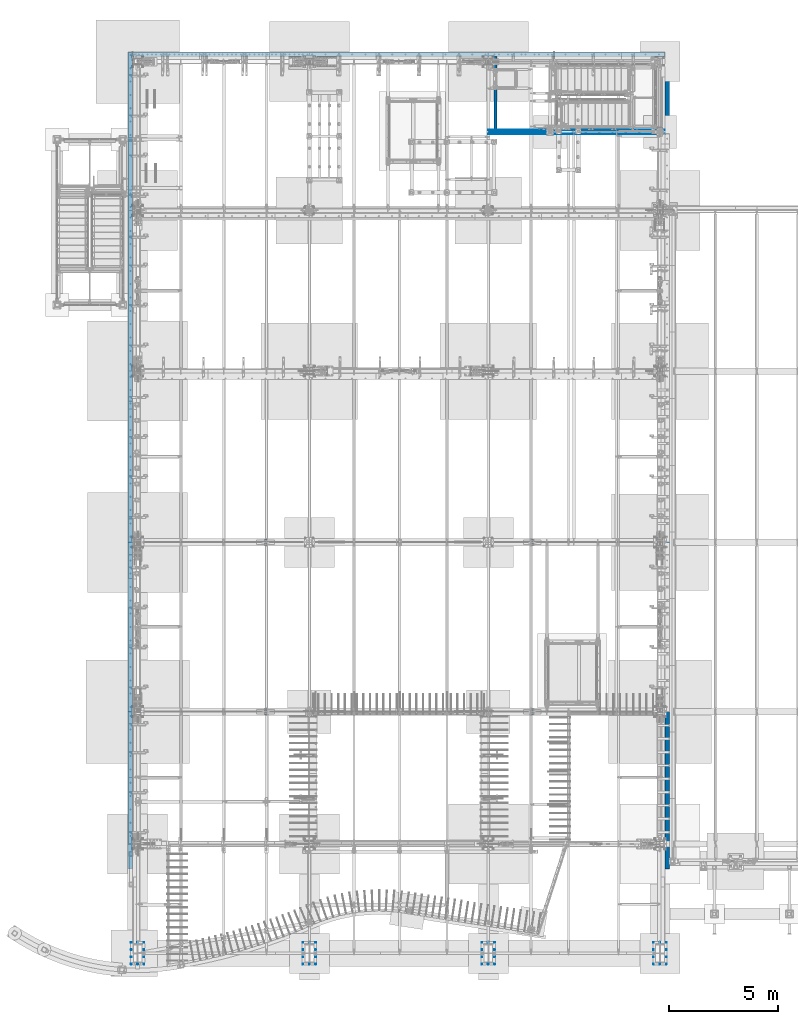
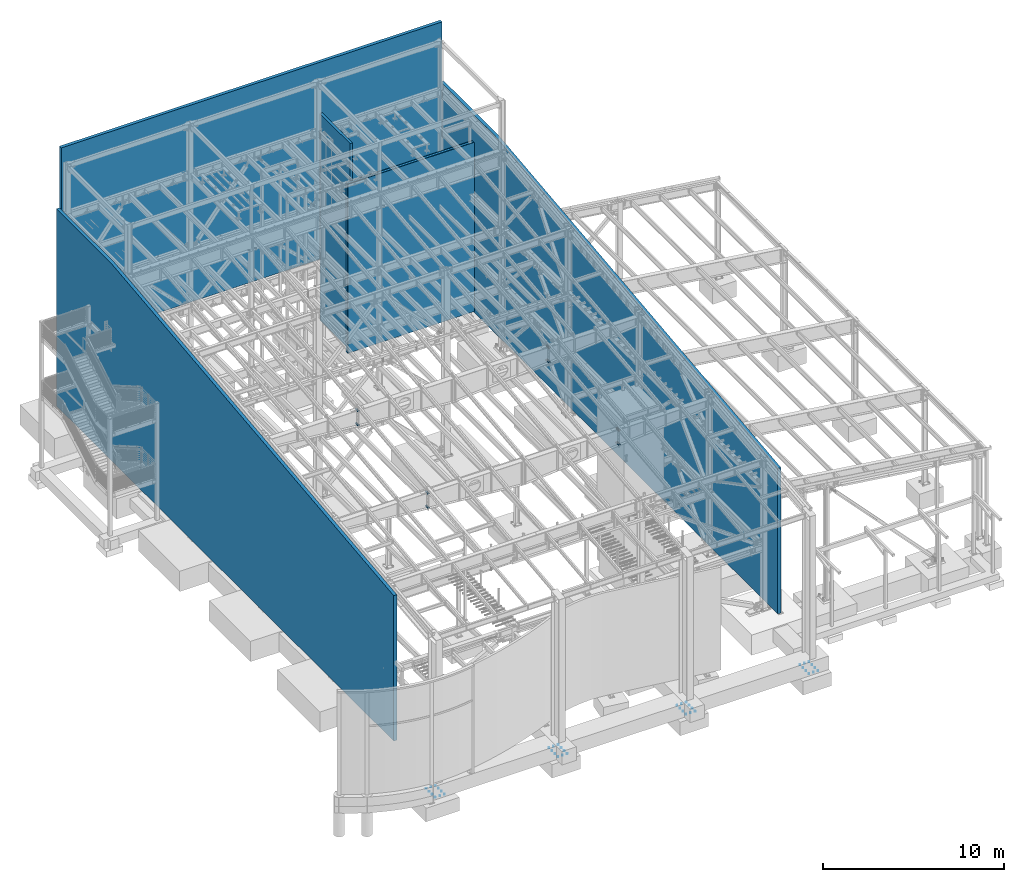
# One storey, part 1 of 1179: 9 walls, 8 mechanical fasteners, 17 elements without a shape of their own.
"""IFC2X3 building model written with IfcOpenShell, lengths in millimetres."""

import ifcopenshell
import ifcopenshell.guid

model = None  # the IFC model being written
_history = None  # IfcOwnerHistory: only IFC2X3 demands one
_inside = {}  # id of a spatial element -> (the spatial element, [elements in it])
_under = {}  # id of a project, library or spatial element -> (it, [spatial elements below it])
_declared = {}  # id of a project -> (the project, [libraries it declares])
_typed = {}  # id of a type object -> (the type object, [elements of that type])
_made_of = {}  # id of a material, layer set ... -> (it, [elements and type objects made of it])


def new_model(schema):
    """Start an empty IFC model of exactly this schema.

    Asked for "IFC4X3", IfcOpenShell would pick the latest addendum, in which some entities
    have other attributes; the version numbers below select the first issue.
    IFC2X3 requires an IfcOwnerHistory on every rooted entity: one is made here for all.
    """
    global model, _history
    if schema == "IFC4X3":
        model = ifcopenshell.file(schema_version=(4, 3, 0, 0))
    else:
        model = ifcopenshell.file(schema=schema)
    _inside.clear()
    _under.clear()
    _declared.clear()
    _typed.clear()
    _made_of.clear()
    _history = None
    if model.schema == "IFC2X3":
        org = make("IfcOrganization", Name="unknown")
        user = make(
            "IfcPersonAndOrganization",
            ThePerson=make("IfcPerson", FamilyName="unknown"),
            TheOrganization=org,
        )
        app = make(
            "IfcApplication",
            ApplicationDeveloper=org,
            Version="unknown",
            ApplicationFullName="unknown",
            ApplicationIdentifier="unknown",
        )
        _history = make(
            "IfcOwnerHistory",
            OwningUser=user,
            OwningApplication=app,
            ChangeAction="ADDED",
            CreationDate=0,
        )
    return model


def make(cls, **values):
    """One entity of the class cls with the attributes given. An attribute that is None is left unset."""
    return model.create_entity(
        cls, **{name: value for name, value in values.items() if value is not None}
    )


def rooted(cls, **values):
    """An entity with a GlobalId (a new one), such as an element, a storey or a relation."""
    return make(cls, GlobalId=ifcopenshell.guid.new(), OwnerHistory=_history, **values)


def si_unit(unit_type, name, prefix=None):
    """IfcSIUnit, for example si_unit("LENGTHUNIT", "METRE", prefix="MILLI")."""
    return make("IfcSIUnit", UnitType=unit_type, Prefix=prefix, Name=name)


def assignment(units):
    """IfcUnitAssignment: the units of a project."""
    return None if units is None else make("IfcUnitAssignment", Units=units)


def point(xyz):
    """IfcCartesianPoint."""
    return None if xyz is None else make("IfcCartesianPoint", Coordinates=xyz)


def direction(xyz):
    """IfcDirection."""
    return None if xyz is None else make("IfcDirection", DirectionRatios=xyz)


def frame(location, z_axis=None, x_axis=None):
    """IfcAxis2Placement3D, a coordinate frame: its origin and axes. An axis left out is left unset."""
    return make(
        "IfcAxis2Placement3D",
        Location=point(location),
        Axis=direction(z_axis),
        RefDirection=direction(x_axis),
    )


def origin_with_axes():
    """The frame at (0, 0, 0) with the z axis (0, 0, 1) and the x axis (1, 0, 0) written out."""
    return frame((0.0, 0.0, 0.0), z_axis=(0.0, 0.0, 1.0), x_axis=(1.0, 0.0, 0.0))


def place(relative_to, where):
    """IfcLocalPlacement: puts the frame where relative to a parent placement (None: the world)."""
    return make(
        "IfcLocalPlacement", PlacementRelTo=relative_to, RelativePlacement=where
    )


def context(
    kind, dimensions, precision=None, world=None, true_north=None, identifier=None
):
    """IfcGeometricRepresentationContext, for example the 3D "Model" context."""
    return make(
        "IfcGeometricRepresentationContext",
        ContextIdentifier=identifier,
        ContextType=kind,
        CoordinateSpaceDimension=dimensions,
        Precision=precision,
        WorldCoordinateSystem=world,
        TrueNorth=true_north,
    )


def subcontext(parent, identifier, kind, view, scale=None):
    """IfcGeometricRepresentationSubContext, for example "Body" below "Model"."""
    return make(
        "IfcGeometricRepresentationSubContext",
        ContextIdentifier=identifier,
        ContextType=kind,
        ParentContext=parent,
        TargetScale=scale,
        TargetView=view,
    )


def project(units=None, contexts=None):
    """IfcProject with its units and contexts."""
    return rooted(
        "IfcProject",
        Name="project",
        RepresentationContexts=contexts,
        UnitsInContext=assignment(units),
    )


def spatial(cls, under=None, at=None, **own):
    """A site, building, storey or space (cls), placed at a placement, below another one or the project."""
    s = rooted(cls, ObjectPlacement=at, **own)
    if under is not None:
        _under.setdefault(under.id(), (under, []))[1].append(s)
    return s


def faces_of(points, faces, orient=None, outer=None):
    """IfcFace entities. A face is a list of loops; a loop is a list of indices into points, from 0.

    orient and outer hold one flag for each loop. By default every Orientation is true, the
    first loop of a face is its IfcFaceOuterBound and the others are IfcFaceBound.
    """
    made = []
    for i, loops in enumerate(faces):
        bounds = []
        for j, loop in enumerate(loops):
            is_outer = j == 0 if outer is None else outer[i][j]
            bounds.append(
                make(
                    "IfcFaceOuterBound" if is_outer else "IfcFaceBound",
                    Bound=make("IfcPolyLoop", Polygon=[points[k] for k in loop]),
                    Orientation=True if orient is None else orient[i][j],
                )
            )
        made.append(make("IfcFace", Bounds=bounds))
    return made


def faceted_brep(points, faces, orient=None, outer=None, voids=None):
    """IfcFacetedBrep: a solid bounded by flat faces; with voids (closed shells), ...WithVoids."""
    shared = [point(p) for p in points]
    hull = make("IfcClosedShell", CfsFaces=faces_of(shared, faces, orient, outer))
    if voids is None:
        return make("IfcFacetedBrep", Outer=hull)
    return make(
        "IfcFacetedBrepWithVoids",
        Outer=hull,
        Voids=[
            make(cls, CfsFaces=faces_of(shared, fs, o, b)) for cls, fs, o, b in voids
        ],
    )


def shape(context_of_items, identifier, shape_type, items):
    """IfcShapeRepresentation: the items that make up one representation, for example the "Body"."""
    return make(
        "IfcShapeRepresentation",
        ContextOfItems=context_of_items,
        RepresentationIdentifier=identifier,
        RepresentationType=shape_type,
        Items=items,
    )


def source(mapping_origin, context_of_items, identifier, shape_type, items):
    """IfcRepresentationMap: a shape defined once, which mapped items show again and again."""
    return make(
        "IfcRepresentationMap",
        MappingOrigin=mapping_origin,
        MappedRepresentation=shape(context_of_items, identifier, shape_type, items),
    )


def transform(
    local_origin,
    x_axis=None,
    y_axis=None,
    z_axis=None,
    scale=None,
    scale2=None,
    scale3=None,
    uniform=True,
):
    """IfcCartesianTransformationOperator3D, or its non-uniform kind. x_axis, y_axis, z_axis: its Axis1, 2, 3."""
    if uniform:
        return make(
            "IfcCartesianTransformationOperator3D",
            Axis1=direction(x_axis),
            Axis2=direction(y_axis),
            LocalOrigin=point(local_origin),
            Scale=scale,
            Axis3=direction(z_axis),
        )
    return make(
        "IfcCartesianTransformationOperator3DnonUniform",
        Axis1=direction(x_axis),
        Axis2=direction(y_axis),
        LocalOrigin=point(local_origin),
        Scale=scale,
        Axis3=direction(z_axis),
        Scale2=scale2,
        Scale3=scale3,
    )


def mapped(mapping_source, mapping_target):
    """IfcMappedItem: shows the shape of a source again, moved by a transform."""
    return make(
        "IfcMappedItem", MappingSource=mapping_source, MappingTarget=mapping_target
    )


def material(Name=None, Category=None):
    """IfcMaterial."""
    return make("IfcMaterial", Name=Name, Category=Category)


def made_of(thing, what):
    """Note that an element or type object is made of a material, layer set ...; save() writes the relation."""
    if what is not None:
        _made_of.setdefault(what.id(), (what, []))[1].append(thing)
    return thing


def type_object(cls, material=None, **own):
    """A type object (cls), such as IfcWallType, which elements share."""
    return made_of(rooted(cls, **own), material)


def element(
    cls,
    number,
    at=None,
    inside=None,
    cuts=None,
    type_object=None,
    material=None,
    context=None,
    identifier="Body",
    shape_type=None,
    held_by="IfcProductDefinitionShape",
    body=None,
    shapes=None,
    **own,
):
    """One element of the class cls, such as IfcWall. Its Tag is "e" and its number.

    at: its placement. inside: the storey or other place that contains it. cuts: it is an
    opening in that element (IfcRelVoidsElement). A single representation is given by context,
    identifier, shape_type and body (its items); several are given by shapes. held_by: the class
    of the entity that holds the representations. save() writes the other relations.
    """
    e = rooted(cls, Tag="e%d" % number, ObjectPlacement=at, **own)
    if body is not None:
        shapes = [shape(context, identifier, shape_type, body)]
    if shapes is not None:
        e.Representation = make(held_by, Representations=shapes)
    if inside is not None:
        _inside.setdefault(inside.id(), (inside, []))[1].append(e)
    if cuts is not None:
        rooted(
            "IfcRelVoidsElement", RelatingBuildingElement=cuts, RelatedOpeningElement=e
        )
    if type_object is not None:
        _typed.setdefault(type_object.id(), (type_object, []))[1].append(e)
    return made_of(e, material)


def aggregate(whole, parts):
    """IfcRelAggregates: a whole, such as a stair, and the parts it consists of."""
    return rooted("IfcRelAggregates", RelatingObject=whole, RelatedObjects=parts)


def save(model, path):
    """Write the relations noted so far, then the file.

    IfcRelAggregates (storeys below a building ...), IfcRelContainedInSpatialStructure (elements
    in a storey), IfcRelDefinesByType, IfcRelAssociatesMaterial and IfcRelDeclares: one each for
    every whole, place, type object, material and project.
    """
    for whole, parts in _under.values():
        aggregate(whole, parts)
    for where, things in _inside.values():
        rooted(
            "IfcRelContainedInSpatialStructure",
            RelatedElements=things,
            RelatingStructure=where,
        )
    for kind, things in _typed.values():
        rooted("IfcRelDefinesByType", RelatedObjects=things, RelatingType=kind)
    for what, things in _made_of.values():
        rooted("IfcRelAssociatesMaterial", RelatedObjects=things, RelatingMaterial=what)
    for by, libraries in _declared.values():
        rooted("IfcRelDeclares", RelatingContext=by, RelatedDefinitions=libraries)
    model.write(path)


model = new_model("IFC2X3")

# Units and contexts
model_context = context("Model", 3, precision=1e-05, world=origin_with_axes())
body_context = subcontext(model_context, "Body", "Model", "MODEL_VIEW")
ifc_project = project(units=[si_unit("LENGTHUNIT", "METRE", prefix="MILLI"), si_unit("AREAUNIT", "SQUARE_METRE"), si_unit("VOLUMEUNIT", "CUBIC_METRE"), si_unit("MASSUNIT", "GRAM", prefix="KILO"), si_unit("TIMEUNIT", "SECOND"), si_unit("PLANEANGLEUNIT", "RADIAN"), si_unit("SOLIDANGLEUNIT", "STERADIAN"), si_unit("THERMODYNAMICTEMPERATUREUNIT", "DEGREE_CELSIUS"), si_unit("LUMINOUSINTENSITYUNIT", "LUMEN")], contexts=[model_context])

# Site, building, storey
site_placement = place(None, origin_with_axes())
site = spatial("IfcSite", under=ifc_project, at=site_placement, CompositionType="ELEMENT")
building_placement = place(site_placement, origin_with_axes())
building = spatial("IfcBuilding", under=site, at=building_placement, Name="Undefined", CompositionType="ELEMENT")
storey_placement = place(building_placement, origin_with_axes())
storey = spatial("IfcBuildingStorey", under=building, at=storey_placement, Name="Undefined", CompositionType="ELEMENT", Elevation=0.0)

# Assembly, wall
assembly_1_placement = place(storey_placement, origin_with_axes())
assembly_1 = element("IfcElementAssembly", 1, at=assembly_1_placement, inside=storey, Name="GYP. BOARD", AssemblyPlace="NOTDEFINED", PredefinedType="REINFORCEMENT_UNIT")
ifc_material_1 = material(Name="CONCRETE/5000")
wall_type_1 = type_object("IfcWallType", PredefinedType="NOTDEFINED")
wall_1_placement = place(assembly_1_placement, frame((16459.2, 37901.5625000252, 5715.0), z_axis=(0.0, 0.0, 1.0), x_axis=(1.0, 0.0, 0.0)))
wall_1 = element("IfcWall", 2, at=wall_1_placement, type_object=wall_type_1, material=ifc_material_1, Name="GYP. BOARD", context=body_context, shape_type="Brep", body=[
    faceted_brep([(0.0, 7.9375, -5715.0), (0.0, 7.9375, 5715.0), (8077.2, 7.9375, 5715.0), (8077.2, 7.9375, -5715.0), (0.0, -7.9375, 5715.0), (8077.2, -7.9375, 5715.0), (0.0, -7.9375, -5715.0), (8077.2, -7.9375, -5715.0)], [[[0, 1, 2, 3]], [[1, 4, 5, 2]], [[4, 6, 7, 5]], [[6, 0, 3, 7]], [[5, 7, 3, 2]], [[6, 4, 1, 0]]]),
])
aggregate(assembly_1, [wall_1])

assembly_2_placement = place(storey_placement, origin_with_axes())
assembly_2 = element("IfcElementAssembly", 3, at=assembly_2_placement, inside=storey, Name="GYP. BOARD", AssemblyPlace="NOTDEFINED", PredefinedType="REINFORCEMENT_UNIT")
wall_2_placement = place(assembly_2_placement, frame((16459.2, 37885.6875000252, 5715.0), z_axis=(0.0, 0.0, 1.0), x_axis=(1.0, 0.0, 0.0)))
wall_2 = element("IfcWall", 4, at=wall_2_placement, type_object=wall_type_1, material=ifc_material_1, Name="GYP. BOARD", context=body_context, shape_type="Brep", body=[
    faceted_brep([(0.0, 7.9375, -5715.0), (0.0, 7.9375, 5715.0), (8077.2, 7.9375, 5715.0), (8077.2, 7.9375, -5715.0), (0.0, -7.9375, 5715.0), (8077.2, -7.9375, 5715.0), (0.0, -7.9375, -5715.0), (8077.2, -7.9375, -5715.0)], [[[0, 1, 2, 3]], [[1, 4, 5, 2]], [[4, 6, 7, 5]], [[6, 0, 3, 7]], [[5, 7, 3, 2]], [[6, 4, 1, 0]]]),
])
aggregate(assembly_2, [wall_2])

assembly_3_placement = place(storey_placement, origin_with_axes())
assembly_3 = element("IfcElementAssembly", 5, at=assembly_3_placement, inside=storey, Name="GYP. BOARD", AssemblyPlace="NOTDEFINED", PredefinedType="REINFORCEMENT_UNIT")
wall_3_placement = place(assembly_3_placement, frame((16459.2, 38085.7125, 5715.0), z_axis=(0.0, 0.0, 1.0), x_axis=(1.0, 0.0, 0.0)))
wall_3 = element("IfcWall", 6, at=wall_3_placement, type_object=wall_type_1, material=ifc_material_1, Name="GYP. BOARD", context=body_context, shape_type="Brep", body=[
    faceted_brep([(0.0, 7.9375, -5715.0), (0.0, 7.9375, 5715.0), (8077.2, 7.9375, 5715.0), (8077.2, 7.9375, -5715.0), (0.0, -7.9375, 5715.0), (8077.2, -7.9375, 5715.0), (0.0, -7.9375, -5715.0), (8077.2, -7.9375, -5715.0)], [[[0, 1, 2, 3]], [[1, 4, 5, 2]], [[4, 6, 7, 5]], [[6, 0, 3, 7]], [[5, 7, 3, 2]], [[6, 4, 1, 0]]]),
])
aggregate(assembly_3, [wall_3])

assembly_4_placement = place(storey_placement, origin_with_axes())
assembly_4 = element("IfcElementAssembly", 7, at=assembly_4_placement, inside=storey, Name="GYP. BOARD", AssemblyPlace="NOTDEFINED", PredefinedType="REINFORCEMENT_UNIT")
wall_4_placement = place(assembly_4_placement, frame((16459.2, 38069.8375, 5715.0), z_axis=(0.0, 0.0, 1.0), x_axis=(1.0, 0.0, 0.0)))
wall_4 = element("IfcWall", 8, at=wall_4_placement, type_object=wall_type_1, material=ifc_material_1, Name="GYP. BOARD", context=body_context, shape_type="Brep", body=[
    faceted_brep([(0.0, 7.9375, -5715.0), (0.0, 7.9375, 5715.0), (8077.2, 7.9375, 5715.0), (8077.2, 7.9375, -5715.0), (0.0, -7.9375, 5715.0), (8077.2, -7.9375, 5715.0), (0.0, -7.9375, -5715.0), (8077.2, -7.9375, -5715.0)], [[[0, 1, 2, 3]], [[1, 4, 5, 2]], [[4, 6, 7, 5]], [[6, 0, 3, 7]], [[5, 7, 3, 2]], [[6, 4, 1, 0]]]),
])
aggregate(assembly_4, [wall_4])

assembly_5_placement = place(storey_placement, origin_with_axes())
assembly_5 = element("IfcElementAssembly", 9, at=assembly_5_placement, inside=storey, Name="WALL", AssemblyPlace="NOTDEFINED", PredefinedType="REINFORCEMENT_UNIT")
wall_type_2 = type_object("IfcWallType", PredefinedType="NOTDEFINED")
wall_5_placement = place(assembly_5_placement, frame((203.199999999999, 41529.0, 10760.075), z_axis=(0.0, 0.0, 1.0), x_axis=(1.0, 0.0, 0.0)))
wall_5 = element("IfcWall", 10, at=wall_5_placement, type_object=wall_type_2, material=ifc_material_1, Name="WALL", context=body_context, shape_type="Brep", body=[
    faceted_brep([(0.0, 101.599999999999, -6657.975), (0.0, 101.599999999999, 6657.975), (24333.2007038869, 101.599999999999, 6657.975), (24333.2007038869, 101.599999999999, -6657.975), (0.0, -101.599999999999, 6657.975), (24333.2007038869, -101.599999999999, 6657.975), (0.0, -101.599999999999, -6657.975), (24333.2007038869, -101.599999999999, -6657.975)], [[[0, 1, 2, 3]], [[1, 4, 5, 2]], [[4, 6, 7, 5]], [[6, 0, 3, 7]], [[5, 7, 3, 2]], [[6, 4, 1, 0]]]),
])
aggregate(assembly_5, [wall_5])

assembly_6_placement = place(storey_placement, origin_with_axes())
assembly_6 = element("IfcElementAssembly", 11, at=assembly_6_placement, inside=storey, Name="WALL", AssemblyPlace="NOTDEFINED", PredefinedType="REINFORCEMENT_UNIT")
wall_6_placement = place(assembly_6_placement, frame((101.599999999999, 4292.60000000001, 6594.475), z_axis=(0.0, 0.0, 1.0), x_axis=(0.0, 1.0, 0.0)))
wall_6 = element("IfcWall", 12, at=wall_6_placement, type_object=wall_type_2, material=ifc_material_1, Name="WALL", context=body_context, shape_type="Brep", body=[
    faceted_brep([(0.0, -101.599999999999, -6657.975), (0.0, 101.599999999999, -6657.975), (37338.0, 101.6, -6657.975), (37338.0, -101.6, -6657.975), (37338.0, -101.6, 6657.975), (37338.0, 101.6, 6657.975), (31293.1291769072, -101.6, 6657.975), (0.0, -101.6, 3163.4294703688), (0.0, 101.6, 3163.4294703688), (31293.1291769072, 101.6, 6657.975)], [[[0, 1, 2, 3]], [[4, 3, 2, 5]], [[0, 3, 4, 6, 7]], [[1, 0, 7, 8]], [[5, 2, 1, 8, 9]], [[4, 5, 9, 6]], [[8, 7, 6, 9]]]),
])
aggregate(assembly_6, [wall_6])

assembly_7_placement = place(storey_placement, origin_with_axes())
assembly_7 = element("IfcElementAssembly", 13, at=assembly_7_placement, inside=storey, Name="WALL", AssemblyPlace="NOTDEFINED", PredefinedType="REINFORCEMENT_UNIT")
wall_7_placement = place(assembly_7_placement, frame((24638.0007038869, 4292.6, 6594.475), z_axis=(0.0, 0.0, 1.0), x_axis=(0.0, 1.0, 0.0)))
wall_7 = element("IfcWall", 14, at=wall_7_placement, type_object=wall_type_2, material=ifc_material_1, Name="WALL", context=body_context, shape_type="Brep", body=[
    faceted_brep([(0.0, -101.599999999999, -6657.975), (0.0, 101.599999999999, -6657.975), (37338.0, 101.6, -6657.975), (37338.0, -101.6, -6657.975), (37338.0, -101.6, 6657.975), (37338.0, 101.6, 6657.975), (31293.1291769072, -101.6, 6657.975), (0.0, -101.6, 3163.4294703688), (0.0, 101.6, 3163.4294703688), (31293.1291769072, 101.6, 6657.975)], [[[0, 1, 2, 3]], [[4, 3, 2, 5]], [[0, 3, 4, 6, 7]], [[1, 0, 7, 8]], [[5, 2, 1, 8, 9]], [[4, 5, 9, 6]], [[8, 7, 6, 9]]]),
])
aggregate(assembly_7, [wall_7])

assembly_8_placement = place(storey_placement, origin_with_axes())
assembly_8 = element("IfcElementAssembly", 15, at=assembly_8_placement, inside=storey, Name="WALL", AssemblyPlace="NOTDEFINED", PredefinedType="REINFORCEMENT_UNIT")
wall_type_3 = type_object("IfcWallType", PredefinedType="NOTDEFINED")
wall_8_placement = place(assembly_8_placement, frame((16789.4, 38061.9, 6985.0), z_axis=(0.0, 0.0, 1.0), x_axis=(0.0, 1.0, 0.0)))
wall_8 = element("IfcWall", 16, at=wall_8_placement, type_object=wall_type_3, material=ifc_material_1, Name="WALL", context=body_context, shape_type="Brep", body=[
    faceted_brep([(0.0, 76.2000000000007, -6985.0), (0.0, 76.2000000000007, 6985.0), (3365.50000000001, 76.2000000000007, 6985.0), (3365.50000000001, 76.2000000000007, -6985.0), (0.0, -76.2000000000007, 6985.0), (3365.50000000001, -76.2000000000007, 6985.0), (0.0, -76.2000000000007, -6985.0), (3365.50000000001, -76.2000000000007, -6985.0)], [[[0, 1, 2, 3]], [[1, 4, 5, 2]], [[4, 6, 7, 5]], [[6, 0, 3, 7]], [[5, 7, 3, 2]], [[6, 4, 1, 0]]]),
])
aggregate(assembly_8, [wall_8])

assembly_9_placement = place(storey_placement, origin_with_axes())
assembly_9 = element("IfcElementAssembly", 17, at=assembly_9_placement, inside=storey, Name="WALL", AssemblyPlace="NOTDEFINED", PredefinedType="REINFORCEMENT_UNIT")
wall_type_4 = type_object("IfcWallType", PredefinedType="NOTDEFINED")
wall_9_placement = place(assembly_9_placement, frame((16459.2, 37985.7, 5715.0), z_axis=(0.0, 0.0, 1.0), x_axis=(1.0, 0.0, 0.0)))
wall_9 = element("IfcWall", 18, at=wall_9_placement, type_object=wall_type_4, material=ifc_material_1, Name="WALL", context=body_context, shape_type="Brep", body=[
    faceted_brep([(0.0, 76.1999999999971, -5715.0), (0.0, 76.1999999999971, 5715.0), (8077.2, 76.1999999999971, 5715.0), (8077.2, 76.1999999999971, -5715.0), (0.0, -76.1999999999971, 5715.0), (8077.2, -76.1999999999971, 5715.0), (0.0, -76.1999999999971, -5715.0), (8077.2, -76.1999999999971, -5715.0)], [[[0, 1, 2, 3]], [[1, 4, 5, 2]], [[4, 6, 7, 5]], [[6, 0, 3, 7]], [[5, 7, 3, 2]], [[6, 4, 1, 0]]]),
])
aggregate(assembly_9, [wall_9])

# Assembly, mechanical fastener
assembly_10_placement = place(storey_placement, origin_with_axes())
assembly_10 = element("IfcElementAssembly", 19, at=assembly_10_placement, inside=storey, Name="RAFTER BEAM", AssemblyPlace="NOTDEFINED", PredefinedType="RIGID_FRAME")
ifc_material_2 = material(Name="Undefined")
mechanical_fastener_type = type_object("IfcMechanicalFastenerType", Name="Bolt assembly")
shared_shape_1 = source(origin_with_axes(), body_context, "Body", "Brep", [
    faceted_brep([(17.9605119723985, -40.4812501907356, 0.0), (12.6999998092651, -40.4812501907356, 12.6999998092651), (1.09976417490228e-15, -40.4812501907356, 17.9605119723985), (-12.6999998092651, -40.4812501907356, 12.6999998092651), (-17.9605119723985, -40.4812501907356, 2.19952834980455e-15), (-12.6999998092651, -40.4812501907356, -12.6999998092651), (-3.29929252470683e-15, -40.4812501907356, -17.9605119723985), (12.6999998092651, -40.4812501907356, -12.6999998092651), (20.6375007629394, -25.4000000000007, -20.6375007629395), (-5.36135063136961e-15, -25.4000000000007, -29.1858334724341), (-20.6375007629395, -25.4000000000007, -20.6375007629394), (-29.1858334724341, -25.4000000000007, 3.57423375424641e-15), (-20.6375007629394, -25.4000000000007, 20.6375007629395), (1.7871168771232e-15, -25.4000000000007, 29.1858334724341), (20.6375007629395, -25.4000000000007, 20.6375007629395), (29.1858334724341, -25.4000000000007, 0.0), (12.6999998092651, -25.4000000000007, 0.0), (10.9985224628809, -25.4000000000007, 6.34999990463295), (6.34999990463181, -25.4000000000007, 10.9985224628816), (-1.31614667686587e-12, -25.4000000000007, 12.6999998092651), (-6.34999990463409, -25.4000000000007, 10.9985224628803), (-10.9985224628822, -25.4000000000007, 6.34999990463067), (-12.6999998092651, -25.4000000000007, -2.63229335373174e-12), (-10.9985224628796, -25.4000000000007, -6.34999990463522), (-6.34999990462954, -25.4000000000007, -10.9985224628829), (3.93434019839663e-12, -25.4000000000007, -12.6999998092651), (6.34999990463636, -25.4000000000007, -10.9985224628789), (10.9985224628835, -25.4000000000007, -6.34999990462839), (10.9985224628835, 63.5000015258782, -6.34999990462839), (6.34999990463636, 63.5000015258782, -10.9985224628789), (3.93434019839663e-12, 63.5000015258782, -12.6999998092651), (-6.34999990462954, 63.5000015258782, -10.9985224628829), (-10.9985224628796, 63.5000015258782, -6.34999990463522), (-12.6999998092651, 63.5000015258782, -2.63229335373174e-12), (-10.9985224628822, 63.5000015258782, 6.34999990463067), (-6.34999990463409, 63.5000015258782, 10.9985224628803), (-1.31614667686587e-12, 63.5000015258782, 12.6999998092651), (6.34999990463181, 63.5000015258782, 10.9985224628816), (10.9985224628809, 63.5000015258782, 6.34999990463295), (12.6999998092651, 63.5000015258782, 0.0), (25.3999996185303, 25.4000000000007, 0.0), (21.9970449257618, 25.4000000000007, 12.6999998092659), (12.6999998092636, 25.4000000000007, 21.9970449257631), (0.0, 25.3999999999996, 25.4000000000015), (-12.6999998092682, 25.4000000000007, 21.9970449257605), (-21.9970449257645, 25.4000000000007, 12.6999998092613), (-25.3999996185303, 25.4000000000007, -5.26458670746348e-12), (-21.9970449257592, 25.4000000000007, -12.6999998092704), (-12.6999998092591, 25.4000000000007, -21.9970449257658), (0.0, 25.3999999999996, -25.4000000000015), (12.6999998092727, 25.4000000000007, -21.9970449257579), (21.9970449257671, 25.4000000000007, -12.6999998092568), (21.9970449257671, 28.7734400272377, -12.6999998092568), (12.6999998092727, 28.7734400272377, -21.9970449257579), (7.86868039679326e-12, 28.7734400272377, -25.3999996185303), (-12.6999998092591, 28.7734400272377, -21.9970449257658), (-21.9970449257592, 28.7734400272377, -12.6999998092704), (-25.3999996185303, 28.7734400272377, -5.26458670746348e-12), (-21.9970449257645, 28.7734400272377, 12.6999998092613), (-12.6999998092682, 28.7734400272377, 21.9970449257605), (-2.63229335373174e-12, 28.7734400272377, 25.3999996185303), (12.6999998092636, 28.7734400272377, 21.9970449257631), (21.9970449257618, 28.7734400272377, 12.6999998092659), (25.3999996185303, 28.7734400272377, 0.0), (23.8301332417684, 28.7734400272377, 0.0), (11.9150666208842, 28.7734400272377, 20.6375007629395), (-11.9150666208842, 28.7734400272377, 20.6375007629395), (-23.8301332417684, 28.7734400272377, 2.91834963977866e-15), (-11.9150666208842, 28.7734400272377, -20.6375007629394), (11.9150666208842, 28.7734400272377, -20.6375007629395), (11.9150666208842, 54.1734396457679, -20.6375007629395), (-11.9150666208842, 54.1734396457679, -20.6375007629394), (-23.8301332417684, 54.1734396457679, 2.91834963977866e-15), (-11.9150666208842, 54.1734396457679, 20.6375007629395), (11.9150666208842, 54.1734396457679, 20.6375007629395), (23.8301332417684, 54.1734396457679, 0.0)], [[[0, 1, 2, 3, 4, 5, 6, 7]], [[8, 9, 10, 11, 12, 13, 14, 15]], [[0, 15, 14, 1]], [[1, 14, 13, 2]], [[2, 13, 12, 3]], [[3, 12, 11, 4]], [[4, 11, 10, 5]], [[5, 10, 9, 6]], [[6, 9, 8, 7]], [[7, 8, 15, 0]], [[16, 17, 18, 19, 20, 21, 22, 23, 24, 25, 26, 27]], [[28, 29, 30, 31, 32, 33, 34, 35, 36, 37, 38, 39]], [[16, 39, 38, 17]], [[17, 38, 37, 18]], [[18, 37, 36, 19]], [[19, 36, 35, 20]], [[20, 35, 34, 21]], [[21, 34, 33, 22]], [[22, 33, 32, 23]], [[23, 32, 31, 24]], [[24, 31, 30, 25]], [[25, 30, 29, 26]], [[26, 29, 28, 27]], [[27, 28, 39, 16]], [[40, 41, 42, 43, 44, 45, 46, 47, 48, 49, 50, 51]], [[52, 53, 54, 55, 56, 57, 58, 59, 60, 61, 62, 63]], [[40, 63, 62, 41]], [[41, 62, 61, 42]], [[42, 61, 60, 43]], [[43, 60, 59, 44]], [[44, 59, 58, 45]], [[45, 58, 57, 46]], [[46, 57, 56, 47]], [[47, 56, 55, 48]], [[48, 55, 54, 49]], [[49, 54, 53, 50]], [[50, 53, 52, 51]], [[51, 52, 63, 40]], [[64, 65, 66, 67, 68, 69]], [[70, 71, 72, 73, 74, 75]], [[64, 75, 74, 65]], [[65, 74, 73, 66]], [[66, 73, 72, 67]], [[67, 72, 71, 68]], [[68, 71, 70, 69]], [[69, 70, 75, 64]]]),
    faceted_brep([(13.4937496185303, -0.0999999999992753, 0.0), (11.6859299619536, -0.0999999999992753, 6.74687480926554), (6.74687480926433, -0.0999999999992753, 11.6859299619543), (-1.39840582563885e-12, -0.0999999999992753, 13.4937496185303), (-6.74687480926675, -0.0999999999992753, 11.6859299619529), (-11.685929961955, -0.0999999999992753, 6.74687480926312), (-13.4937496185303, -0.0999999999992753, -2.79681165127771e-12), (-11.6859299619522, -0.0999999999992753, -6.74687480926796), (-6.74687480926191, -0.0999999999992753, -11.6859299619557), (4.18023640540155e-12, -0.0999999999992753, -13.4937496185303), (6.74687480926917, -0.0999999999992753, -11.6859299619515), (11.6859299619564, -0.0999999999992753, -6.7468748092607), (11.6859299619564, 25.4000000000007, -6.7468748092607), (6.74687480926917, 25.4000000000007, -11.6859299619515), (4.18023640540155e-12, 25.4000000000007, -13.4937496185303), (-6.74687480926191, 25.4000000000007, -11.6859299619557), (-11.6859299619522, 25.4000000000007, -6.74687480926796), (-13.4937496185303, 25.4000000000007, -2.79681165127771e-12), (-11.685929961955, 25.4000000000007, 6.74687480926312), (-6.74687480926675, 25.4000000000007, 11.6859299619529), (-1.39840582563885e-12, 25.4000000000007, 13.4937496185303), (6.74687480926433, 25.4000000000007, 11.6859299619543), (11.6859299619536, 25.4000000000007, 6.74687480926554), (13.4937496185303, 25.4000000000007, 0.0), (13.4937496185303, -25.3000000000007, 0.0), (11.6859299619536, -25.3000000000007, 6.74687480926554), (6.74687480926433, -25.3000000000007, 11.6859299619543), (-1.39840582563885e-12, -25.3000000000007, 13.4937496185303), (-6.74687480926675, -25.3000000000007, 11.6859299619529), (-11.685929961955, -25.3000000000007, 6.74687480926312), (-13.4937496185303, -25.3000000000007, -2.79681165127771e-12), (-11.6859299619522, -25.3000000000007, -6.74687480926796), (-6.74687480926191, -25.3000000000007, -11.6859299619557), (4.18023640540155e-12, -25.3000000000007, -13.4937496185303), (6.74687480926917, -25.3000000000007, -11.6859299619515), (11.6859299619564, -25.3000000000007, -6.7468748092607), (11.6859299619564, 0.0999999999992767, -6.7468748092607), (6.74687480926917, 0.0999999999992767, -11.6859299619515), (4.18023640540155e-12, 0.0999999999992767, -13.4937496185303), (-6.74687480926191, 0.0999999999992767, -11.6859299619557), (-11.6859299619522, 0.0999999999992767, -6.74687480926796), (-13.4937496185303, 0.0999999999992767, -2.79681165127771e-12), (-11.685929961955, 0.0999999999992767, 6.74687480926312), (-6.74687480926675, 0.0999999999992767, 11.6859299619529), (-1.39840582563885e-12, 0.0999999999992767, 13.4937496185303), (6.74687480926433, 0.0999999999992767, 11.6859299619543), (11.6859299619536, 0.0999999999992767, 6.74687480926554), (13.4937496185303, 0.0999999999992767, 0.0)], [[[0, 1, 2, 3, 4, 5, 6, 7, 8, 9, 10, 11]], [[12, 13, 14, 15, 16, 17, 18, 19, 20, 21, 22, 23]], [[0, 23, 22, 1]], [[1, 22, 21, 2]], [[2, 21, 20, 3]], [[3, 20, 19, 4]], [[4, 19, 18, 5]], [[5, 18, 17, 6]], [[6, 17, 16, 7]], [[7, 16, 15, 8]], [[8, 15, 14, 9]], [[9, 14, 13, 10]], [[10, 13, 12, 11]], [[11, 12, 23, 0]], [[24, 25, 26, 27, 28, 29, 30, 31, 32, 33, 34, 35]], [[36, 37, 38, 39, 40, 41, 42, 43, 44, 45, 46, 47]], [[24, 47, 46, 25]], [[25, 46, 45, 26]], [[26, 45, 44, 27]], [[27, 44, 43, 28]], [[28, 43, 42, 29]], [[29, 42, 41, 30]], [[30, 41, 40, 31]], [[31, 40, 39, 32]], [[32, 39, 38, 33]], [[33, 38, 37, 34]], [[34, 37, 36, 35]], [[35, 36, 47, 24]]]),
])
mechanical_fastener_1_placement = place(assembly_10_placement, frame((18465.8, 11607.8093353614, 9698.05885710149), z_axis=(0.0, 0.0, 1.0), x_axis=(0.0, -1.0, 0.0)))
mechanical_fastener_1 = element("IfcMechanicalFastener", 20, at=mechanical_fastener_1_placement, type_object=mechanical_fastener_type, material=ifc_material_2, Name="Bolt assembly", NominalDiameter=25.3999996185303, NominalLength=88.9000015258789, context=body_context, shape_type="MappedRepresentation", body=[
    mapped(shared_shape_1, transform((0.0, 0.0, -481.015014500001))),
    mapped(shared_shape_1, transform((76.2000000000007, 0.0, -481.015014500001))),
    mapped(shared_shape_1, transform((177.799999999999, 0.0, -481.015014500001))),
    mapped(shared_shape_1, transform((254.0, 0.0, -481.015014500001))),
    mapped(shared_shape_1, transform((0.0, 0.0, 481.015014500001))),
    mapped(shared_shape_1, transform((76.2000000000007, 0.0, 481.015014500001))),
    mapped(shared_shape_1, transform((177.799999999999, 0.0, 481.015014500001))),
    mapped(shared_shape_1, transform((254.0, 0.0, 481.015014500001))),
])
aggregate(assembly_10, [mechanical_fastener_1])

assembly_11_placement = place(storey_placement, origin_with_axes())
assembly_11 = element("IfcElementAssembly", 21, at=assembly_11_placement, inside=storey, Name="RAFTER BEAM", AssemblyPlace="NOTDEFINED", PredefinedType="RIGID_FRAME")
mechanical_fastener_2_placement = place(assembly_11_placement, frame((6273.80003875008, 11607.8095363738, 9698.05885710149), z_axis=(0.0, 0.0, 1.0), x_axis=(0.0, -1.0, 0.0)))
mechanical_fastener_2 = element("IfcMechanicalFastener", 22, at=mechanical_fastener_2_placement, type_object=mechanical_fastener_type, material=ifc_material_2, Name="Bolt assembly", NominalDiameter=25.3999996185303, NominalLength=88.9000015258789, context=body_context, shape_type="MappedRepresentation", body=[
    mapped(shared_shape_1, transform((0.0, 0.0, -481.015014500001))),
    mapped(shared_shape_1, transform((76.2000000000007, 0.0, -481.015014500001))),
    mapped(shared_shape_1, transform((177.799999999999, 0.0, -481.015014500001))),
    mapped(shared_shape_1, transform((254.0, 0.0, -481.015014500001))),
    mapped(shared_shape_1, transform((0.0, 0.0, 481.015014500001))),
    mapped(shared_shape_1, transform((76.2000000000007, 0.0, 481.015014500001))),
    mapped(shared_shape_1, transform((177.799999999999, 0.0, 481.015014500001))),
    mapped(shared_shape_1, transform((254.0, 0.0, 481.015014500001))),
])
aggregate(assembly_11, [mechanical_fastener_2])

assembly_12_placement = place(storey_placement, origin_with_axes())
assembly_12 = element("IfcElementAssembly", 23, at=assembly_12_placement, inside=storey, Name="RAFTER BEAM", AssemblyPlace="NOTDEFINED", PredefinedType="RIGID_FRAME")
mechanical_fastener_3_placement = place(assembly_12_placement, frame((18465.8, 19354.7999999987, 10573.54375), z_axis=(0.0, 0.0, 1.0), x_axis=(0.0, -1.0, 0.0)))
mechanical_fastener_3 = element("IfcMechanicalFastener", 24, at=mechanical_fastener_3_placement, type_object=mechanical_fastener_type, material=ifc_material_2, Name="Bolt assembly", NominalDiameter=25.3999996185303, NominalLength=88.9000015258789, context=body_context, shape_type="MappedRepresentation", body=[
    mapped(shared_shape_1, transform((0.0, 0.0, -481.015014500001))),
    mapped(shared_shape_1, transform((76.2000000000007, 0.0, -481.015014500001))),
    mapped(shared_shape_1, transform((177.799999999999, 0.0, -481.015014500001))),
    mapped(shared_shape_1, transform((254.0, 0.0, -481.015014500001))),
    mapped(shared_shape_1, transform((0.0, 0.0, 481.015014500001))),
    mapped(shared_shape_1, transform((76.2000000000007, 0.0, 481.015014500001))),
    mapped(shared_shape_1, transform((177.799999999999, 0.0, 481.015014500001))),
    mapped(shared_shape_1, transform((254.0, 0.0, 481.015014500001))),
])
aggregate(assembly_12, [mechanical_fastener_3])

assembly_13_placement = place(storey_placement, origin_with_axes())
assembly_13 = element("IfcElementAssembly", 25, at=assembly_13_placement, inside=storey, Name="RAFTER BEAM", AssemblyPlace="NOTDEFINED", PredefinedType="RIGID_FRAME")
mechanical_fastener_4_placement = place(assembly_13_placement, frame((6273.80003875008, 19354.8002010111, 10573.54375), z_axis=(0.0, 0.0, 1.0), x_axis=(0.0, -1.0, 0.0)))
mechanical_fastener_4 = element("IfcMechanicalFastener", 26, at=mechanical_fastener_4_placement, type_object=mechanical_fastener_type, material=ifc_material_2, Name="Bolt assembly", NominalDiameter=25.3999996185303, NominalLength=88.9000015258789, context=body_context, shape_type="MappedRepresentation", body=[
    mapped(shared_shape_1, transform((0.0, 0.0, -481.015014500001))),
    mapped(shared_shape_1, transform((76.2000000000007, 0.0, -481.015014500001))),
    mapped(shared_shape_1, transform((177.799999999999, 0.0, -481.015014500001))),
    mapped(shared_shape_1, transform((254.0, 0.0, -481.015014500001))),
    mapped(shared_shape_1, transform((0.0, 0.0, 481.015014500001))),
    mapped(shared_shape_1, transform((76.2000000000007, 0.0, 481.015014500001))),
    mapped(shared_shape_1, transform((177.799999999999, 0.0, 481.015014500001))),
    mapped(shared_shape_1, transform((254.0, 0.0, 481.015014500001))),
])
aggregate(assembly_13, [mechanical_fastener_4])

assembly_14_placement = place(storey_placement, origin_with_axes())
assembly_14 = element("IfcElementAssembly", 27, at=assembly_14_placement, inside=storey, Name="COLUMN", AssemblyPlace="NOTDEFINED", PredefinedType="RIGID_FRAME")
shared_shape_2 = source(origin_with_axes(), body_context, "Body", "Brep", [
    faceted_brep([(16.6687507629395, -38.1, 0.0), (14.4355616100565, -38.1, 8.33437538147022), (8.33437538146873, -38.1, 14.4355616100574), (-1.7274426183962e-12, -38.1, 16.6687507629395), (-8.33437538147172, -38.1, 14.4355616100557), (-14.4355616100582, -38.1, 8.33437538146724), (-16.6687507629395, -38.1, -3.4548852367924e-12), (-14.4355616100548, -38.1, -8.33437538147321), (-8.33437538146575, -38.1, -14.4355616100591), (5.16382182429984e-12, -38.1, -16.6687507629395), (8.3343753814747, -38.1, -14.4355616100539), (14.43556161006, -38.1, -8.33437538146425), (14.43556161006, 0.100000000000016, -8.33437538146425), (8.3343753814747, 0.100000000000016, -14.4355616100539), (5.16382182429984e-12, 0.100000000000016, -16.6687507629395), (-8.33437538146575, 0.100000000000016, -14.4355616100591), (-14.4355616100548, 0.100000000000016, -8.33437538147321), (-16.6687507629395, 0.100000000000016, -3.4548852367924e-12), (-14.4355616100582, 0.100000000000016, 8.33437538146724), (-8.33437538147172, 0.100000000000016, 14.4355616100557), (-1.7274426183962e-12, 0.100000000000016, 16.6687507629395), (8.33437538146873, 0.100000000000016, 14.4355616100574), (14.4355616100565, 0.100000000000016, 8.33437538147022), (16.6687507629395, 0.100000000000016, 0.0)], [[[0, 1, 2, 3, 4, 5, 6, 7, 8, 9, 10, 11]], [[12, 13, 14, 15, 16, 17, 18, 19, 20, 21, 22, 23]], [[0, 23, 22, 1]], [[1, 22, 21, 2]], [[2, 21, 20, 3]], [[3, 20, 19, 4]], [[4, 19, 18, 5]], [[5, 18, 17, 6]], [[6, 17, 16, 7]], [[7, 16, 15, 8]], [[8, 15, 14, 9]], [[9, 14, 13, 10]], [[10, 13, 12, 11]], [[11, 12, 23, 0]]]),
])
mechanical_fastener_5_placement = place(assembly_14_placement, frame((7988.3, 933.449999998597, -1257.3), z_axis=(-1.60200000027544e-06, -0.999999999998717, 0.0), x_axis=(0.999999999998717, -1.60199999998034e-06, 0.0)))
mechanical_fastener_5 = element("IfcMechanicalFastener", 28, at=mechanical_fastener_5_placement, type_object=mechanical_fastener_type, material=ifc_material_2, Name="Bolt assembly", NominalDiameter=25.3999996185303, NominalLength=38.0999984741211, context=body_context, shape_type="MappedRepresentation", body=[
    mapped(shared_shape_2, transform((0.0, 0.0, 0.0))),
    mapped(shared_shape_2, transform((292.100006103733, 0.0, -1.99293026525993e-10))),
    mapped(shared_shape_2, transform((584.200012207467, 0.0, -3.98472366214264e-10))),
    mapped(shared_shape_2, transform((1.87355908565223e-10, 0.0, 330.200012207053))),
    mapped(shared_shape_2, transform((584.200012207656, 0.0, 330.200012206654))),
    mapped(shared_shape_2, transform((3.74711817130446e-10, 0.0, 660.400024414106))),
    mapped(shared_shape_2, transform((584.200012207843, 0.0, 660.400024413707))),
    mapped(shared_shape_2, transform((5.62977220397443e-10, 0.0, 990.599975586002))),
    mapped(shared_shape_2, transform((292.100006104297, 0.0, 990.599975585803))),
    mapped(shared_shape_2, transform((584.200012208031, 0.0, 990.599975585604))),
])
aggregate(assembly_14, [mechanical_fastener_5])

assembly_15_placement = place(storey_placement, origin_with_axes())
assembly_15 = element("IfcElementAssembly", 29, at=assembly_15_placement, inside=storey, Name="COLUMN", AssemblyPlace="NOTDEFINED", PredefinedType="RIGID_FRAME")
mechanical_fastener_6_placement = place(assembly_15_placement, frame((16167.1, 933.449999998597, -1257.3), z_axis=(-1.60200000027544e-06, -0.999999999998717, 0.0), x_axis=(0.999999999998717, -1.60199999998034e-06, 0.0)))
mechanical_fastener_6 = element("IfcMechanicalFastener", 30, at=mechanical_fastener_6_placement, type_object=mechanical_fastener_type, material=ifc_material_2, Name="Bolt assembly", NominalDiameter=25.3999996185303, NominalLength=38.0999984741211, context=body_context, shape_type="MappedRepresentation", body=[
    mapped(shared_shape_2, transform((0.0, 0.0, 0.0))),
    mapped(shared_shape_2, transform((292.100006103733, 0.0, -1.99293026525993e-10))),
    mapped(shared_shape_2, transform((584.200012207467, 0.0, -3.98472366214264e-10))),
    mapped(shared_shape_2, transform((1.87355908565223e-10, 0.0, 330.200012207053))),
    mapped(shared_shape_2, transform((584.200012207656, 0.0, 330.200012206654))),
    mapped(shared_shape_2, transform((3.74711817130446e-10, 0.0, 660.400024414106))),
    mapped(shared_shape_2, transform((584.200012207843, 0.0, 660.400024413707))),
    mapped(shared_shape_2, transform((5.62977220397443e-10, 0.0, 990.599975586002))),
    mapped(shared_shape_2, transform((292.100006104297, 0.0, 990.599975585803))),
    mapped(shared_shape_2, transform((584.200012208031, 0.0, 990.599975585604))),
])
aggregate(assembly_15, [mechanical_fastener_6])

assembly_16_placement = place(storey_placement, origin_with_axes())
assembly_16 = element("IfcElementAssembly", 31, at=assembly_16_placement, inside=storey, Name="COLUMN", AssemblyPlace="NOTDEFINED", PredefinedType="RIGID_FRAME")
mechanical_fastener_7_placement = place(assembly_16_placement, frame((24015.7, 933.449999998597, -1257.3), z_axis=(-1.60200000027544e-06, -0.999999999998717, 0.0), x_axis=(0.999999999998717, -1.60199999998034e-06, 0.0)))
mechanical_fastener_7 = element("IfcMechanicalFastener", 32, at=mechanical_fastener_7_placement, type_object=mechanical_fastener_type, material=ifc_material_2, Name="Bolt assembly", NominalDiameter=25.3999996185303, NominalLength=38.0999984741211, context=body_context, shape_type="MappedRepresentation", body=[
    mapped(shared_shape_2, transform((0.0, 0.0, 0.0))),
    mapped(shared_shape_2, transform((292.100006103733, 0.0, -1.99293026525993e-10))),
    mapped(shared_shape_2, transform((584.200012207467, 0.0, -3.98472366214264e-10))),
    mapped(shared_shape_2, transform((1.87355908565223e-10, 0.0, 330.200012207053))),
    mapped(shared_shape_2, transform((584.200012207656, 0.0, 330.200012206654))),
    mapped(shared_shape_2, transform((3.74711817130446e-10, 0.0, 660.400024414106))),
    mapped(shared_shape_2, transform((584.200012207843, 0.0, 660.400024413707))),
    mapped(shared_shape_2, transform((5.62977220397443e-10, 0.0, 990.599975586002))),
    mapped(shared_shape_2, transform((292.100006104297, 0.0, 990.599975585803))),
    mapped(shared_shape_2, transform((584.200012208031, 0.0, 990.599975585604))),
])
aggregate(assembly_16, [mechanical_fastener_7])

assembly_17_placement = place(storey_placement, origin_with_axes())
assembly_17 = element("IfcElementAssembly", 33, at=assembly_17_placement, inside=storey, Name="COLUMN", AssemblyPlace="NOTDEFINED", PredefinedType="RIGID_FRAME")
mechanical_fastener_8_placement = place(assembly_17_placement, frame((139.7, 933.449999998597, -1257.3), z_axis=(-1.60200000027544e-06, -0.999999999998717, 0.0), x_axis=(0.999999999998717, -1.60199999998034e-06, 0.0)))
mechanical_fastener_8 = element("IfcMechanicalFastener", 34, at=mechanical_fastener_8_placement, type_object=mechanical_fastener_type, material=ifc_material_2, Name="Bolt assembly", NominalDiameter=25.3999996185303, NominalLength=38.0999984741211, context=body_context, shape_type="MappedRepresentation", body=[
    mapped(shared_shape_2, transform((0.0, 0.0, 0.0))),
    mapped(shared_shape_2, transform((292.100006103733, 0.0, -1.99293026525993e-10))),
    mapped(shared_shape_2, transform((584.200012207467, 0.0, -3.98472366214264e-10))),
    mapped(shared_shape_2, transform((1.87355908565223e-10, 0.0, 330.200012207053))),
    mapped(shared_shape_2, transform((584.200012207656, 0.0, 330.200012206654))),
    mapped(shared_shape_2, transform((3.74711817130446e-10, 0.0, 660.400024414106))),
    mapped(shared_shape_2, transform((584.200012207843, 0.0, 660.400024413707))),
    mapped(shared_shape_2, transform((5.62977220397443e-10, 0.0, 990.599975586002))),
    mapped(shared_shape_2, transform((292.100006104297, 0.0, 990.599975585803))),
    mapped(shared_shape_2, transform((584.200012208031, 0.0, 990.599975585604))),
])
aggregate(assembly_17, [mechanical_fastener_8])

save(model, "model.ifc")
